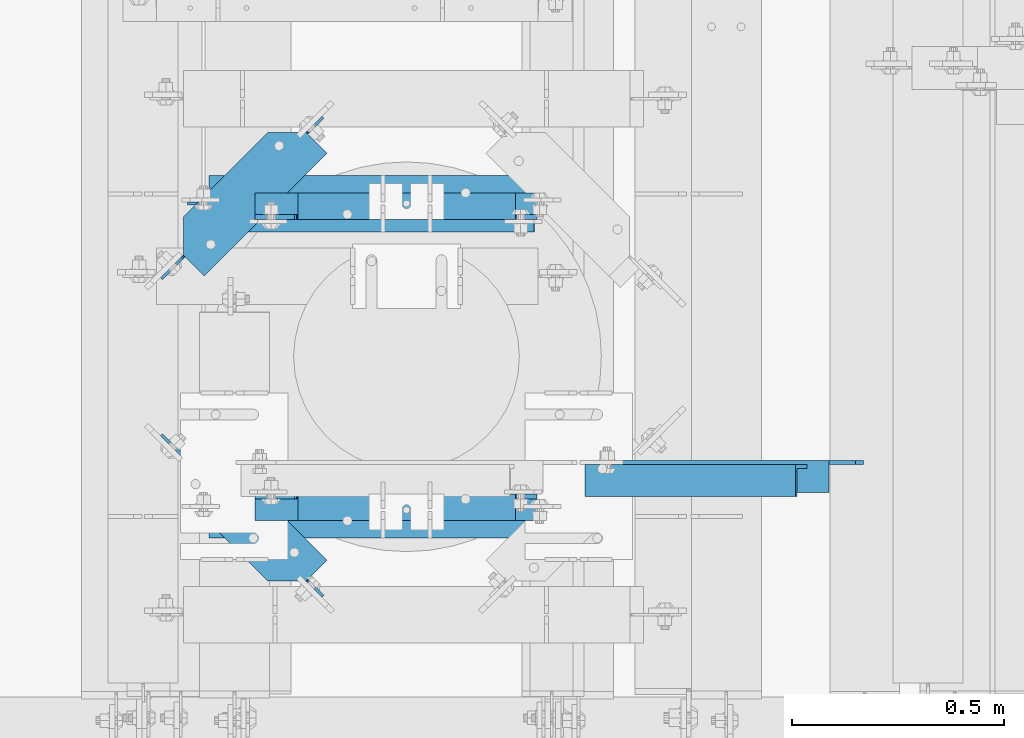
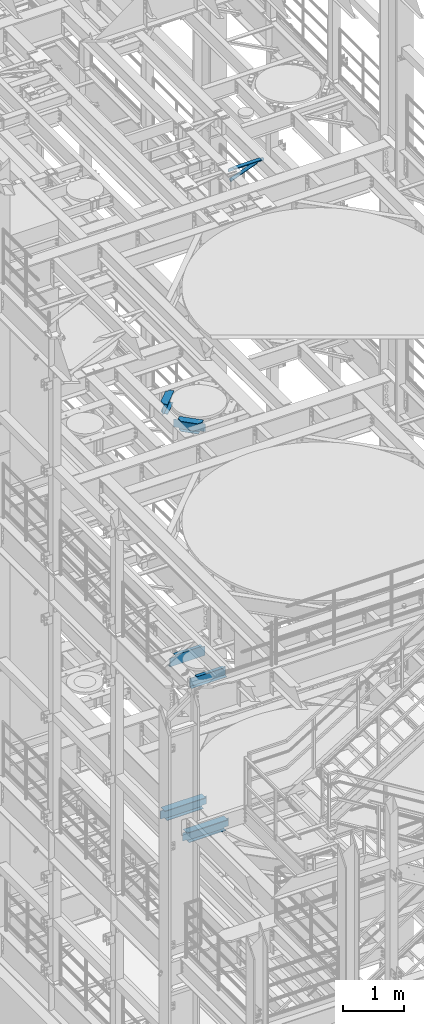
# One storey, part 1259 of 1876: 7 beams, 1 member, 8 elements without a shape of their own.
"""IFC2X3 building model written with IfcOpenShell, lengths in millimetres."""

from ifc_helpers import new_model, si_unit, frame, origin_with_axes, place, context, subcontext, project, spatial, faceted_brep, material, type_object, element, aggregate, save


model = new_model("IFC2X3")

# Units and contexts
model_context = context("Model", 3, precision=1e-05, world=origin_with_axes())
body_context = subcontext(model_context, "Body", "Model", "MODEL_VIEW")
ifc_project = project(units=[si_unit("LENGTHUNIT", "METRE", prefix="MILLI"), si_unit("AREAUNIT", "SQUARE_METRE"), si_unit("VOLUMEUNIT", "CUBIC_METRE"), si_unit("MASSUNIT", "GRAM", prefix="KILO"), si_unit("TIMEUNIT", "SECOND"), si_unit("PLANEANGLEUNIT", "RADIAN"), si_unit("SOLIDANGLEUNIT", "STERADIAN"), si_unit("THERMODYNAMICTEMPERATUREUNIT", "DEGREE_CELSIUS"), si_unit("LUMINOUSINTENSITYUNIT", "LUMEN")], contexts=[model_context])

# Site, building, storey
site_placement = place(None, origin_with_axes())
site = spatial("IfcSite", under=ifc_project, at=site_placement, CompositionType="ELEMENT")
building_placement = place(site_placement, origin_with_axes())
building = spatial("IfcBuilding", under=site, at=building_placement, Name="Undefined", CompositionType="ELEMENT")
storey_placement = place(building_placement, origin_with_axes())
storey = spatial("IfcBuildingStorey", under=building, at=storey_placement, Name="Undefined", CompositionType="ELEMENT", Elevation=0.0)

# Assembly, member
assembly_1_placement = place(storey_placement, origin_with_axes())
assembly_1 = element("IfcElementAssembly", 1, at=assembly_1_placement, inside=storey, AssemblyPlace="NOTDEFINED", PredefinedType="RIGID_FRAME")
ifc_material_1 = material(Name="STEEL/A36")
member_type = type_object("IfcMemberType", Name="L3X3X3/8", PredefinedType="NOTDEFINED")
member_placement = place(assembly_1_placement, frame((4825.99943782548, 2149.47737292659, 17722.85), z_axis=(0.0, -1.0, 0.0), x_axis=(0.933232749162593, -9.69999853849769e-08, 0.35927237006263)))
member = element("IfcMember", 2, at=member_placement, type_object=member_type, material=ifc_material_1, ObjectType="L3X3X3/8", context=body_context, shape_type="Brep", body=[
    faceted_brep([(31.6783539145181, 38.0999999999167, -38.1000000000035), (31.6783539102435, 38.1000000000477, 38.0999999999967), (563.830812318436, 38.100000000677, 38.0999999999349), (563.830812322711, 38.1000000005497, -38.1000000000654), (31.6783539102325, 28.5750000000644, 38.0999999999967), (563.830812318425, 28.5750000006938, 38.0999999999349), (31.6783539139742, 28.5749999999498, -28.5750000000039), (563.830812322169, 28.575000000581, -28.5750000000658), (31.6783539139069, -38.0999999999422, -28.5750000000044), (563.830812322098, -38.0999999993164, -28.5750000000662), (31.6783539144417, -38.099999999964, -38.1000000000045), (563.830812322634, -38.0999999993292, -38.1000000000663)], [[[0, 1, 2, 3]], [[1, 4, 5, 2]], [[4, 6, 7, 5]], [[6, 8, 9, 7]], [[8, 10, 11, 9]], [[10, 0, 3, 11]], [[5, 7, 9, 11, 3, 2]], [[10, 8, 6, 4, 1, 0]]]),
])
aggregate(assembly_1, [member])

# Assembly, beam
assembly_2_placement = place(storey_placement, origin_with_axes())
assembly_2 = element("IfcElementAssembly", 3, at=assembly_2_placement, inside=storey, Name="ANGLE", AssemblyPlace="NOTDEFINED", PredefinedType="RIGID_FRAME")
beam_type_1 = type_object("IfcBeamType", Name="L3X3X3/8", PredefinedType="NOTDEFINED")
beam_1_placement = place(assembly_2_placement, frame((4826.00006225236, 2159.00237292652, 17945.1), z_axis=(0.0, -1.0, 0.0), x_axis=(1.0, 0.0, 0.0)))
beam_1 = element("IfcBeam", 4, at=beam_1_placement, type_object=beam_type_1, material=ifc_material_1, Name="ANGLE", ObjectType="L3X3X3/8", context=body_context, shape_type="Brep", body=[
    faceted_brep([(592.137879206581, 28.5750000000007, -28.5750000001131), (592.137886141031, 28.5750000000007, 38.0999999998871), (84.1369379238226, 28.5750017223108, 38.099999999984), (84.1369309896222, 28.5750000000007, -28.5750000000166), (592.137552829826, 38.0999999999985, 38.0999999998871), (84.1373129237786, 38.0999999999985, 38.0999999999835), (22.2249324870172, 28.5750000000007, -28.5750000000048), (22.2249314964174, 28.5750108662178, -38.1000000000049), (3.17493225935686, 9.52501162915723, -38.1000000000013), (3.17493324995667, 9.52501048616614, -28.5750000000012), (84.1369299990224, 28.5750108662141, -38.1000000000167), (84.1373049986182, 38.0999999999985, -38.1000000000167), (592.13754490474, 38.0999999999985, -38.1000000001131), (592.137934775866, 26.9870022607502, -28.5750000001131), (592.137933785266, 26.9870012415704, -38.1000000001131), (654.049937080378, 26.9870022607502, -28.5750000001249), (654.049936089778, 26.9870012415704, -38.100000000125), (673.099936317439, 7.93700302368961, -28.5750000001285), (673.099935326839, 7.93700200450985, -38.1000000001286), (673.099936317439, 1.58700264221989, -28.5750000001285), (673.099935326839, 1.58700162304012, -38.1000000001286), (673.099934791558, -38.0999999999985, -28.5750000001285), (673.099933800958, -38.0999999999985, -38.1000000001286), (3.17493098964678, -38.0999999999985, -28.5750000000012), (3.17492999904698, -38.0999999999985, -38.1000000000013), (3.17492847316589, 3.17501220136182, -38.1000000000013), (3.17492946376569, 3.17501105837073, -28.5750000000012)], [[[0, 1, 2, 3]], [[1, 4, 5, 2]], [[6, 7, 8, 9]], [[3, 10, 7, 6]], [[2, 5, 11, 10, 3]], [[4, 12, 11, 5]], [[1, 0, 13, 14, 12, 4]], [[15, 16, 14, 13]], [[17, 18, 16, 15]], [[19, 20, 18, 17]], [[20, 19, 21, 22]], [[22, 21, 23, 24]], [[8, 7, 10, 11, 12, 14, 16, 18, 20, 22, 24, 25]], [[9, 8, 25, 26]], [[21, 19, 17, 15, 13, 0, 3, 6, 9, 26, 23]], [[25, 24, 23, 26]]]),
])
aggregate(assembly_2, [beam_1])

assembly_3_placement = place(storey_placement, origin_with_axes())
assembly_3 = element("IfcElementAssembly", 5, at=assembly_3_placement, inside=storey, Name="BEAM", AssemblyPlace="NOTDEFINED", PredefinedType="RIGID_FRAME")
ifc_material_2 = material(Name="STEEL/A992")
beam_type_2 = type_object("IfcBeamType", Name="W8X18", PredefinedType="NOTDEFINED")
beam_2_placement = place(assembly_3_placement, frame((3797.3, 2300.55425635799, 13206.4125), z_axis=(0.0, 0.0, 1.0), x_axis=(0.707104099181461, -0.707109463181462, 0.0)))
beam_2 = element("IfcBeam", 6, at=beam_2_placement, type_object=beam_type_2, material=ifc_material_2, Name="BEAM", ObjectType="W8X18", context=body_context, shape_type="Brep", body=[
    faceted_brep([(61.5469102724485, -3.17500000000564, -77.7875000000004), (61.5469102724435, 3.17499999999382, -77.7875000000004), (137.746380590202, 3.17499999998745, -77.7875000000004), (137.746380590201, -3.17500000001201, -77.7875000000004), (142.606460108247, 3.17499999998745, -78.7542299225879), (142.606460108246, -3.17500000001291, -78.7542299225879), (146.7266365764, 3.17499999998745, -81.5072438230654), (146.7266365764, -3.17500000001291, -81.5072438230654), (149.479650476878, 3.17499999998654, -85.6274202912191), (149.479650476877, -3.17500000001291, -85.6274202912191), (150.446380399465, -3.17500000001291, -90.4874998092655), (150.446380399465, 3.17499999998654, -90.4874998092655), (150.446380399465, 3.17499999998654, -95.25), (150.446380399471, 66.6749999999847, -95.25), (150.446380399471, 66.6749999999847, -103.1875), (150.446380399464, -15.7419074005238, -103.1875), (150.446380399464, -15.741907400522, -95.25), (150.446380399465, -3.17500000001291, -95.25), (483.741355979041, -66.6750000000384, -103.1875), (483.741355979041, -66.6750000000384, -95.25), (201.379858527849, -66.6750000000102, -95.25), (201.379858527849, -66.6750000000147, -103.1875), (499.521676769977, -50.8945595016339, -103.1875), (499.521676769977, -50.8945599597382, -95.25), (483.741355979041, -66.6750000000384, 95.25), (483.741355979041, -66.6750000000384, 103.1875), (201.379858527849, -66.6750000000102, 103.1875), (201.379858527849, -66.6750000000147, 95.25), (137.879377876005, -3.17500000001201, 103.1875), (137.879377876005, -3.17500000001201, 95.25), (547.240876123301, -3.17500000004566, 95.25), (547.240876123301, -3.17499815664814, 103.1875), (547.146676769977, 66.674999999952, 103.1875), (137.746380399474, 66.6749999999856, 103.1875), (547.146676769977, 66.674999999952, 95.25), (547.146676769972, 3.1749999999538, 95.25), (137.746380399468, 3.17499999998745, 95.25), (137.746380399474, 66.6749999999856, 95.25), (125.046380590204, -3.1750000000111, 77.7875000000004), (125.046380590204, 3.17499999998836, 77.7875000000004), (61.5469102724435, 3.17499999999382, 77.7875000000004), (61.5469102724485, -3.17500000000564, 77.7875000000004), (129.906460108249, -3.1750000000111, 78.7542299225879), (129.90646010825, 3.17499999998836, 78.7542299225879), (134.026636576402, -3.17500000001201, 81.5072438230654), (134.026636576403, 3.17499999998836, 81.5072438230654), (136.77965047688, -3.17500000001201, 85.6274202912191), (136.779650476881, 3.17499999998745, 85.6274202912191), (137.746380399468, -3.17500000001201, 90.4874998092655), (137.746380399468, 3.17499999998745, 90.4874998092655), (547.146676770065, -3.17499999995425, 90.4874998092655), (547.146676770069, 3.17499997963523, 90.4874998092655), (548.113406692652, -3.17499999995403, 85.6274202912191), (548.113406692656, 3.17499997923346, 85.6274202912191), (550.86642059313, -3.1749999999538, 81.5072438230654), (550.866420593134, 3.17499997889263, 81.5072438230654), (554.986597061284, -3.17499999995357, 78.7542299225879), (554.986597061287, 3.17499997866548, 78.7542299225879), (559.846676579328, -3.17499999995289, 77.7875000000004), (559.846676579332, 3.1749999785859, 77.7875000000004), (601.122206639045, -3.1749999999497, 77.7875000000004), (601.122206639281, 3.1750000000477, 77.7875000000004), (601.122206639045, -3.1749999999497, -77.7875000000004), (601.122206639281, 3.1750000000477, -77.7875000000004), (512.221676579338, -3.17499999995698, -77.7875000000004), (512.221676579342, 3.17499996473862, -77.7875000000004), (507.361597061294, -3.17499999995789, -78.7542299225879), (507.361597061296, 3.17499996467791, -78.7542299225879), (503.24142059314, -3.17499999995721, -81.5072438230654), (503.241420593144, 3.17499996447827, -81.5072438230654), (500.488406692662, -3.17499999995835, -85.6274202912191), (500.488406692665, 3.17499996416927, -85.6274202912191), (499.521676770074, -3.17499999995835, -90.4874998092655), (499.521676770079, 3.17499996379797, -90.4874998092655), (499.521676770028, -3.17499999995789, -95.25), (499.521676769986, 66.6749999999565, -103.1875), (499.521676769986, 66.6749999999565, -95.25), (499.521676770028, 3.17500000003929, -95.25)], [[[0, 1, 2, 3]], [[3, 2, 4, 5]], [[5, 4, 6, 7]], [[7, 6, 8, 9]], [[10, 11, 12, 13, 14, 15, 16, 17]], [[9, 8, 11, 10]], [[18, 19, 20, 21]], [[19, 18, 22, 23]], [[24, 25, 26, 27]], [[27, 26, 28, 29]], [[30, 24, 27, 29]], [[25, 24, 30, 31]], [[26, 25, 31, 32, 33, 28]], [[34, 35, 36, 37]], [[38, 39, 40, 41]], [[42, 43, 39, 38]], [[44, 45, 43, 42]], [[46, 47, 45, 44]], [[48, 49, 47, 46]], [[28, 33, 37, 36, 49, 48, 29]], [[32, 34, 37, 33]], [[31, 30, 50, 51, 35, 34, 32]], [[52, 53, 51, 50]], [[54, 55, 53, 52]], [[56, 57, 55, 54]], [[58, 59, 57, 56]], [[60, 61, 59, 58]], [[61, 60, 62, 63]], [[62, 64, 65, 63]], [[66, 67, 65, 64]], [[68, 69, 67, 66]], [[70, 71, 69, 68]], [[72, 73, 71, 70]], [[74, 23, 22, 75, 76, 77, 73, 72]], [[20, 19, 23, 74, 17, 16]], [[21, 20, 16, 15]], [[75, 22, 18, 21, 15, 14]], [[76, 75, 14, 13]], [[77, 76, 13, 12]], [[6, 4, 2, 1, 40, 39, 43, 45, 47, 49, 36, 35, 51, 53, 55, 57, 59, 61, 63, 65, 67, 69, 71, 73, 77, 12, 11, 8]], [[41, 40, 1, 0]], [[74, 72, 70, 68, 66, 64, 62, 60, 58, 56, 54, 52, 50, 30, 29, 48, 46, 44, 42, 38, 41, 0, 3, 5, 7, 9, 10, 17]]]),
])
aggregate(assembly_3, [beam_2])

assembly_4_placement = place(storey_placement, origin_with_axes())
assembly_4 = element("IfcElementAssembly", 7, at=assembly_4_placement, inside=storey, Name="BEAM", AssemblyPlace="NOTDEFINED", PredefinedType="RIGID_FRAME")
beam_3_placement = place(assembly_4_placement, frame((3797.3, 2582.59574364201, 13206.4125), z_axis=(0.0, 0.0, 1.0), x_axis=(0.707104099181461, 0.707109463181462, 0.0)))
beam_3 = element("IfcBeam", 8, at=beam_3_placement, type_object=beam_type_2, material=ifc_material_2, Name="BEAM", ObjectType="W8X18", context=body_context, shape_type="Brep", body=[
    faceted_brep([(61.5469102724485, -3.17500000000564, 77.7875000000004), (61.5469102724435, 3.17499999999382, 77.7875000000004), (61.5469102724435, 3.17499999999382, -77.7875000000004), (61.5469102724485, -3.17500000000564, -77.7875000000004), (483.741355979063, 66.6750000000156, -103.1875), (499.521676770023, 50.8945595016301, -103.1875), (499.521676770033, -66.6749999999354, -103.1875), (150.446380399347, -66.6749999999852, -103.1875), (150.446380399339, 15.7419074003969, -103.1875), (201.37985852787, 66.6749999999925, -103.1875), (499.521676770033, -66.6749999999354, -95.25), (150.446380399347, -66.6749999999852, -95.25), (499.521676770028, -3.17499999995789, -95.25), (150.446380399465, -3.17500000001291, -95.25), (137.746380590201, -3.17500000001201, -77.7875000000004), (137.746380590202, 3.17499999998745, -77.7875000000004), (142.606460108247, 3.17499999998745, -78.7542299225879), (142.606460108246, -3.17500000001291, -78.7542299225879), (146.7266365764, 3.17499999998745, -81.5072438230654), (146.7266365764, -3.17500000001291, -81.5072438230654), (149.479650476878, 3.17499999998654, -85.6274202912191), (149.479650476877, -3.17500000001291, -85.6274202912191), (150.446380399465, 3.17499999998654, -90.4874998092655), (150.446380399465, -3.17500000001291, -90.4874998092655), (150.446380399465, 3.17499999998654, -95.25), (499.521676770028, 3.17500000003929, -95.25), (499.521676770023, 50.8945599596909, -95.25), (483.741355979063, 66.6750000000156, -95.25), (201.37985852787, 66.6750000000313, -95.25), (150.446380399339, 15.7419074003969, -95.25), (499.521676770079, 3.17499996379797, -90.4874998092655), (499.521676770074, -3.17499999995835, -90.4874998092655), (500.488406692665, 3.17499996416927, -85.6274202912191), (500.488406692662, -3.17499999995835, -85.6274202912191), (503.241420593144, 3.17499996447827, -81.5072438230654), (503.24142059314, -3.17499999995721, -81.5072438230654), (507.361597061296, 3.17499996467791, -78.7542299225879), (507.361597061294, -3.17499999995789, -78.7542299225879), (512.221676579342, 3.17499996473862, -77.7875000000004), (512.221676579338, -3.17499999995698, -77.7875000000004), (601.122206639045, -3.1749999999497, -77.7875000000004), (601.122206639281, 3.1750000000477, -77.7875000000004), (601.122206639281, 3.1750000000477, 77.7875000000004), (601.122206639045, -3.1749999999497, 77.7875000000004), (559.846676579332, 3.1749999785859, 77.7875000000004), (559.846676579328, -3.17499999995289, 77.7875000000004), (554.986597061287, 3.17499997866548, 78.7542299225879), (554.986597061284, -3.17499999995357, 78.7542299225879), (550.866420593134, 3.17499997889263, 81.5072438230654), (550.86642059313, -3.1749999999538, 81.5072438230654), (548.113406692656, 3.17499997923346, 85.6274202912191), (548.113406692652, -3.17499999995403, 85.6274202912191), (547.146676770069, 3.17499997963523, 90.4874998092655), (547.146676770065, -3.17499999995425, 90.4874998092655), (547.146676770018, -3.1749999999538, 95.25), (547.146676770023, -66.6749999999315, 95.25), (137.746380399351, -66.6749999999863, 95.25), (137.746380399345, -3.17499999998813, 95.25), (547.146676770023, -66.6749999999315, 103.1875), (137.746380399351, -66.6749999999863, 103.1875), (137.746380399344, 3.17500000001132, 103.1875), (547.146676769945, 3.26919822458831, 103.1875), (483.741355979063, 66.6750000000156, 103.1875), (201.37985852787, 66.6750000000313, 103.1875), (137.879377390637, 3.17500048591205, 103.1875), (483.741355979063, 66.6750000000156, 95.25), (201.37985852787, 66.6749999999925, 95.25), (547.146676769945, 3.26919822458831, 95.25), (547.146676769972, 3.1749999999538, 95.25), (137.879377390637, 3.17500000000996, 95.25), (137.746380399468, 3.17499999998745, 95.25), (137.746380399468, 3.17499999998745, 90.4874998092655), (137.746380399468, -3.17500000001201, 90.4874998092655), (136.779650476881, 3.17499999998745, 85.6274202912191), (136.77965047688, -3.17500000001201, 85.6274202912191), (134.026636576403, 3.17499999998836, 81.5072438230654), (134.026636576402, -3.17500000001201, 81.5072438230654), (129.90646010825, 3.17499999998836, 78.7542299225879), (129.906460108249, -3.1750000000111, 78.7542299225879), (125.046380590204, 3.17499999998836, 77.7875000000004), (125.046380590204, -3.1750000000111, 77.7875000000004)], [[[0, 1, 2, 3]], [[4, 5, 6, 7, 8, 9]], [[6, 10, 11, 7]], [[10, 12, 13, 11]], [[14, 15, 16, 17]], [[17, 16, 18, 19]], [[19, 18, 20, 21]], [[21, 20, 22, 23]], [[24, 25, 26, 27, 28, 29]], [[7, 11, 13, 23, 22, 24, 29, 8]], [[28, 9, 8, 29]], [[27, 4, 9, 28]], [[4, 27, 26, 5]], [[12, 10, 6, 5, 26, 25, 30, 31]], [[31, 30, 32, 33]], [[33, 32, 34, 35]], [[35, 34, 36, 37]], [[37, 36, 38, 39]], [[40, 39, 38, 41]], [[42, 43, 40, 41]], [[43, 42, 44, 45]], [[45, 44, 46, 47]], [[47, 46, 48, 49]], [[49, 48, 50, 51]], [[51, 50, 52, 53]], [[54, 55, 56, 57]], [[55, 58, 59, 56]], [[60, 59, 58, 61, 62, 63, 64]], [[62, 65, 66, 63]], [[61, 67, 65, 62]], [[58, 55, 54, 53, 52, 68, 67, 61]], [[65, 67, 68, 69, 66]], [[63, 66, 69, 64]], [[64, 69, 70, 60]], [[71, 72, 57, 56, 59, 60, 70]], [[72, 71, 73, 74]], [[74, 73, 75, 76]], [[76, 75, 77, 78]], [[78, 77, 79, 80]], [[14, 17, 19, 21, 23, 13, 12, 31, 33, 35, 37, 39, 40, 43, 45, 47, 49, 51, 53, 54, 57, 72, 74, 76, 78, 80, 0, 3]], [[3, 2, 15, 14]], [[79, 77, 75, 73, 71, 70, 69, 68, 52, 50, 48, 46, 44, 42, 41, 38, 36, 34, 32, 30, 25, 24, 22, 20, 18, 16, 15, 2, 1]], [[80, 79, 1, 0]]]),
])
aggregate(assembly_4, [beam_3])

assembly_5_placement = place(storey_placement, origin_with_axes())
assembly_5 = element("IfcElementAssembly", 9, at=assembly_5_placement, inside=storey, Name="BEAM", AssemblyPlace="NOTDEFINED", PredefinedType="RIGID_FRAME")
beam_4_placement = place(assembly_5_placement, frame((3886.2, 2803.525, 5027.6125), z_axis=(0.0, 0.0, -1.0), x_axis=(1.0, 0.0, 0.0)))
beam_4 = element("IfcBeam", 10, at=beam_4_placement, type_object=beam_type_2, material=ifc_material_2, Name="BEAM", ObjectType="W8X18", context=body_context, shape_type="Brep", body=[
    faceted_brep([(835.025000000001, -66.6750000000002, -103.1875), (835.025000000001, 66.6750000000002, -103.1875), (835.025000000001, 66.6750000000002, -96.837499809264), (835.025000000001, -66.6750000000002, -96.837499809264), (835.340773345276, -3.17500000000018, -95.25), (835.340773345276, -66.6750000000002, -95.25), (835.340773345276, 66.6750000000002, -95.25), (835.340773345276, 3.17500000000018, -95.25), (835.991729922588, 3.17500000000018, -91.9774202912186), (835.991729922588, -3.17500000000018, -91.9774202912186), (838.744743823067, 3.17500000000018, -87.8572438230649), (838.744743823067, -3.17500000000018, -87.8572438230649), (842.86492029122, 3.17500000000018, -85.1042299225865), (842.86492029122, -3.17500000000018, -85.1042299225865), (847.724999809266, 3.17500000000018, -84.1374999999989), (847.724999809266, -3.17500000000018, -84.1374999999989), (885.825000000001, -3.17500000000018, -84.1374999999989), (885.825000000001, 3.17500000000018, -84.1374999999989), (104.775, 3.17500000000018, 95.25), (104.775, 66.6750000000002, 95.25), (796.925000000001, 66.6750000000002, 95.25), (796.925000000001, 3.17500000000018, 95.25), (66.675000000002, -66.6750000000002, -96.837499809264), (66.675000000002, 66.6750000000002, -96.837499809264), (66.675000000002, 66.6750000000002, -103.1875), (66.675000000002, -66.6750000000002, -103.1875), (66.3592266547266, -66.6750000000002, -95.25), (66.3592266547266, -3.17500000000018, -95.25), (65.708270077414, -3.17500000000018, -91.9774202912186), (65.708270077414, 3.17500000000018, -91.9774202912186), (66.3592266547266, 3.17500000000018, -95.25), (66.3592266547266, 66.6750000000002, -95.25), (62.955256176936, -3.17500000000018, -87.8572438230649), (62.955256176936, 3.17500000000018, -87.8572438230649), (58.8350797087824, -3.17500000000018, -85.1042299225865), (58.8350797087824, 3.17500000000018, -85.1042299225865), (53.9750001907369, -3.17500000000018, -84.1374999999989), (53.9750001907369, 3.17500000000018, -84.1374999999989), (15.875, -3.17500000000018, -84.1375000000007), (15.875, 3.17500000000018, -84.1375000000007), (15.875, -3.17500000000018, 77.7874999999949), (15.875, 3.17500000000018, 77.7874999999949), (92.0750001907368, -3.17500000000018, 77.7875000000013), (92.0750001907368, 3.17500000000018, 77.7875000000013), (96.9350797087823, -3.17500000000018, 78.7542299225888), (96.9350797087823, 3.17500000000018, 78.7542299225888), (101.055256176936, -3.17500000000018, 81.5072438230673), (101.055256176936, 3.17500000000018, 81.5072438230673), (103.808270077414, -3.17500000000018, 85.6274202912209), (103.808270077414, 3.17500000000018, 85.6274202912209), (104.775000000002, -3.17500000000018, 90.4874998092664), (104.775000000002, 3.17500000000018, 90.4874998092664), (104.775, -66.6750000000002, 103.1875), (104.775, 66.6750000000002, 103.1875), (104.775, -3.17500000000018, 95.25), (104.775, -66.6750000000002, 95.25), (796.925000000001, -3.17500000000018, 95.25), (796.925000000001, -66.6750000000002, 95.25), (796.925000000001, -66.6750000000002, 103.1875), (796.925000000001, 66.6750000000002, 103.1875), (796.925000000001, -3.17500000000018, 90.4874998092664), (796.925000000001, 3.17500000000018, 90.4874998092664), (797.891729922589, -3.17500000000018, 85.6274202912209), (797.891729922589, 3.17500000000018, 85.6274202912209), (800.644743823067, -3.17500000000018, 81.5072438230673), (800.644743823067, 3.17500000000018, 81.5072438230673), (804.764920291221, -3.17500000000018, 78.7542299225888), (804.764920291221, 3.17500000000018, 78.7542299225888), (809.624999809266, -3.17500000000018, 77.7875000000013), (809.624999809266, 3.17500000000018, 77.7875000000013), (885.825000000001, -3.17500000000018, 77.7875000000013), (885.825000000001, 3.17500000000018, 77.7875000000013)], [[[0, 1, 2, 3]], [[4, 5, 3, 2, 6, 7, 8, 9]], [[9, 8, 10, 11]], [[11, 10, 12, 13]], [[13, 12, 14, 15]], [[16, 15, 14, 17]], [[18, 19, 20, 21]], [[22, 23, 24, 25]], [[26, 27, 28, 29, 30, 31, 23, 22]], [[32, 33, 29, 28]], [[34, 35, 33, 32]], [[36, 37, 35, 34]], [[38, 39, 37, 36]], [[40, 41, 39, 38]], [[42, 43, 41, 40]], [[44, 45, 43, 42]], [[46, 47, 45, 44]], [[48, 49, 47, 46]], [[50, 51, 49, 48]], [[52, 53, 19, 18, 51, 50, 54, 55]], [[55, 54, 56, 57]], [[52, 55, 57, 58]], [[53, 52, 58, 59]], [[19, 53, 59, 20]], [[58, 57, 56, 60, 61, 21, 20, 59]], [[62, 63, 61, 60]], [[64, 65, 63, 62]], [[66, 67, 65, 64]], [[68, 69, 67, 66]], [[70, 71, 69, 68]], [[71, 70, 16, 17]], [[12, 10, 8, 7, 30, 29, 33, 35, 37, 39, 41, 43, 45, 47, 49, 51, 18, 21, 61, 63, 65, 67, 69, 71, 17, 14]], [[31, 30, 7, 6]], [[1, 24, 23, 31, 6, 2]], [[25, 24, 1, 0]], [[26, 22, 25, 0, 3, 5]], [[27, 26, 5, 4]], [[70, 68, 66, 64, 62, 60, 56, 54, 50, 48, 46, 44, 42, 40, 38, 36, 34, 32, 28, 27, 4, 9, 11, 13, 15, 16]]]),
])
aggregate(assembly_5, [beam_4])

assembly_6_placement = place(storey_placement, origin_with_axes())
assembly_6 = element("IfcElementAssembly", 11, at=assembly_6_placement, inside=storey, Name="BEAM", AssemblyPlace="NOTDEFINED", PredefinedType="RIGID_FRAME")
beam_5_placement = place(assembly_6_placement, frame((3886.2, 2079.625, 5027.6125), z_axis=(0.0, 0.0, 1.0), x_axis=(1.0, 0.0, 0.0)))
beam_5 = element("IfcBeam", 12, at=beam_5_placement, type_object=beam_type_2, material=ifc_material_2, Name="BEAM", ObjectType="W8X18", context=body_context, shape_type="Brep", body=[
    faceted_brep([(15.875, -3.17500000000018, -77.7874999999949), (15.875, 3.17500000000018, -77.7874999999949), (92.0750001907354, 3.17500000000018, -77.7875000000022), (92.0750001907354, -3.17500000000018, -77.7875000000022), (96.9350797087809, 3.17500000000018, -78.7542299225897), (96.9350797087809, -3.17500000000018, -78.7542299225897), (101.055256176935, 3.17500000000018, -81.5072438230673), (101.055256176935, -3.17500000000018, -81.5072438230673), (103.808270077413, 3.17500000000018, -85.6274202912209), (103.808270077413, -3.17500000000018, -85.6274202912209), (104.775000000001, -3.17500000000018, -90.4874998092673), (104.775000000001, 3.17500000000018, -90.4874998092673), (104.775000000001, 3.17500000000018, -95.25), (104.775000000001, 66.6750000000002, -95.25), (104.775000000001, 66.6750000000002, -103.1875), (104.775000000001, -66.6750000000002, -103.1875), (104.775000000001, -66.6750000000002, -95.25), (104.775000000001, -3.17500000000018, -95.25), (66.6749999999997, 66.6750000000002, 103.1875), (66.6749999999997, -66.675, 103.1875), (835.024999999998, -66.675, 103.1875), (835.024999999998, 66.6750000000002, 103.1875), (66.6749999999997, 66.6750000000002, 96.837499809264), (66.6749999999997, -66.675, 96.837499809264), (66.3592266547244, -66.675, 95.25), (835.340773345274, -66.675, 95.25), (835.024999999998, -66.675, 96.837499809264), (835.024999999998, 66.6750000000002, 96.837499809264), (66.3592266547244, 66.6750000000002, 95.25), (835.340773345274, 66.6750000000002, 95.25), (66.3592266547244, 3.17500000000018, 95.25), (835.340773345274, 3.17500000000018, 95.25), (53.9750001907346, -3.17500000000018, 84.1374999999989), (53.9750001907346, 3.17500000000018, 84.1374999999989), (15.875, 3.17500000000018, 84.1375000000044), (15.875, -3.17500000000018, 84.1375000000044), (58.8350797087801, -3.17500000000018, 85.1042299225865), (58.8350797087801, 3.17500000000018, 85.1042299225865), (62.9552561769337, -3.17500000000018, 87.8572438230649), (62.9552561769337, 3.17500000000018, 87.8572438230649), (65.7082700774117, -3.17500000000018, 91.9774202912186), (65.7082700774117, 3.17500000000018, 91.9774202912186), (66.3592266547244, -3.17500000000018, 95.25), (835.340773345274, -3.17500000000018, 95.25), (835.991729922586, -3.17500000000018, 91.9774202912186), (835.991729922586, 3.17500000000018, 91.9774202912186), (838.744743823064, -3.17500000000018, 87.8572438230649), (838.744743823064, 3.17500000000018, 87.8572438230649), (842.864920291218, -3.17500000000018, 85.1042299225865), (842.864920291218, 3.17500000000018, 85.1042299225865), (847.724999809263, -3.17500000000018, 84.1374999999989), (847.724999809263, 3.17500000000018, 84.1374999999989), (885.824999999998, -3.17500000000018, 84.1374999999989), (885.824999999998, 3.17500000000018, 84.1374999999989), (885.824999999998, -3.17500000000018, -77.7875000000013), (885.824999999998, 3.17500000000018, -77.7875000000013), (809.624999809264, -3.17500000000018, -77.7875000000013), (809.624999809264, 3.17500000000018, -77.7875000000013), (804.764920291218, -3.17500000000018, -78.7542299225888), (804.764920291218, 3.17500000000018, -78.7542299225888), (800.644743823065, -3.17500000000018, -81.5072438230673), (800.644743823065, 3.17500000000018, -81.5072438230673), (797.891729922586, -3.17500000000018, -85.6274202912209), (797.891729922586, 3.17500000000018, -85.6274202912209), (796.924999999999, -3.17500000000018, -90.4874998092664), (796.924999999999, 3.17500000000018, -90.4874998092664), (796.924999999999, -3.17500000000018, -95.25), (796.924999999999, -66.675, -95.25), (796.924999999999, -66.675, -103.1875), (796.924999999999, 66.6750000000002, -103.1875), (796.924999999999, 66.6750000000002, -95.25), (796.924999999999, 3.17500000000018, -95.25)], [[[0, 1, 2, 3]], [[3, 2, 4, 5]], [[5, 4, 6, 7]], [[7, 6, 8, 9]], [[10, 11, 12, 13, 14, 15, 16, 17]], [[9, 8, 11, 10]], [[18, 19, 20, 21]], [[19, 18, 22, 23]], [[20, 19, 23, 24, 25, 26]], [[20, 26, 27, 21]], [[28, 22, 18, 21, 27, 29]], [[30, 28, 29, 31]], [[32, 33, 34, 35]], [[36, 37, 33, 32]], [[38, 39, 37, 36]], [[40, 41, 39, 38]], [[23, 22, 28, 30, 41, 40, 42, 24]], [[24, 42, 43, 25]], [[44, 45, 31, 29, 27, 26, 25, 43]], [[46, 47, 45, 44]], [[48, 49, 47, 46]], [[50, 51, 49, 48]], [[52, 53, 51, 50]], [[53, 52, 54, 55]], [[54, 56, 57, 55]], [[58, 59, 57, 56]], [[60, 61, 59, 58]], [[62, 63, 61, 60]], [[64, 65, 63, 62]], [[66, 67, 68, 69, 70, 71, 65, 64]], [[67, 66, 17, 16]], [[68, 67, 16, 15]], [[69, 68, 15, 14]], [[70, 69, 14, 13]], [[71, 70, 13, 12]], [[6, 4, 2, 1, 34, 33, 37, 39, 41, 30, 31, 45, 47, 49, 51, 53, 55, 57, 59, 61, 63, 65, 71, 12, 11, 8]], [[35, 34, 1, 0]], [[66, 64, 62, 60, 58, 56, 54, 52, 50, 48, 46, 44, 43, 42, 40, 38, 36, 32, 35, 0, 3, 5, 7, 9, 10, 17]]]),
])
aggregate(assembly_6, [beam_5])

assembly_7_placement = place(storey_placement, origin_with_axes())
assembly_7 = element("IfcElementAssembly", 13, at=assembly_7_placement, inside=storey, Name="BEAM", AssemblyPlace="NOTDEFINED", PredefinedType="RIGID_FRAME")
beam_type_3 = type_object("IfcBeamType", Name="C8X18.75", PredefinedType="NOTDEFINED")
beam_6_placement = place(assembly_7_placement, frame((4070.35, 2797.17216796875, 8051.8), z_axis=(0.0, 0.0, -1.0), x_axis=(1.0, 0.0, 0.0)))
beam_6 = element("IfcBeam", 14, at=beam_6_placement, type_object=beam_type_3, material=ifc_material_1, Name="BEAM", ObjectType="C8X18.75", context=body_context, shape_type="Brep", body=[
    faceted_brep([(-8.73162035838459, 19.0500000000002, -69.8499999999995), (-8.73162035838459, 31.75, -69.8499999999995), (80.1683798323502, 31.75, -69.8499999999995), (80.1683798323502, 19.0500000000002, -69.8499999999995), (85.0284593503957, 31.75, -70.816729922587), (85.0284593503957, 19.0500000000002, -70.816729922587), (89.1486358185493, 31.75, -73.5697438230654), (89.1486358185493, 19.0500000000002, -73.5697438230654), (91.9016497190278, 31.75, -77.6899202912191), (91.9016497190278, 19.0500000000002, -77.6899202912191), (92.8683796416153, 19.0500000000002, -82.5499998092646), (92.8683796416153, 31.75, -82.5499998092646), (92.8683796416153, 31.75, -101.6), (92.8683796416153, -31.75, -101.6), (92.8683796416153, -31.75, -97.3645500000002), (92.8683796416153, 19.0500000000002, -88.9012700000003), (606.425, -31.75, -97.3645500000002), (606.425, -31.75, -101.6), (606.425, 31.75, -101.6), (606.425, 31.75, -95.2499998092644), (606.425, -19.0576219043483, -95.2499998092644), (607.391729922588, 31.75, -90.3899202912189), (607.391729922588, 10.1145240623118, -90.3899202912189), (-8.73162035838459, 31.75, 101.6), (-8.73162035838459, -31.75, 101.6), (657.224999999999, -31.75, 101.6), (657.224999999999, 31.75, 101.6), (-8.73162035838459, -31.75, 97.3645500000002), (657.224999999999, -31.75, 97.3645500000002), (-8.73162035838459, 19.0500000000002, 88.9012700000003), (657.224999999999, 19.0500000000002, 88.9012700000003), (657.224999999999, 19.0500000000002, -82.5499999999993), (657.224999999999, 31.75, -82.5499999999993), (619.124999809265, 19.0500000000002, -82.5499999999993), (619.124999809265, 31.75, -82.5499999999993), (614.26492029122, 19.0500000000002, -83.5167299225868), (614.26492029122, 31.75, -83.5167299225868), (610.144743823066, 19.0500000000002, -86.2697438230653), (610.144743823066, 31.75, -86.2697438230653), (608.386414246513, 19.0500000000002, -88.9012700000003)], [[[0, 1, 2, 3]], [[3, 2, 4, 5]], [[5, 4, 6, 7]], [[7, 6, 8, 9]], [[10, 11, 12, 13, 14, 15]], [[9, 8, 11, 10]], [[16, 17, 18, 19, 20]], [[20, 19, 21, 22]], [[23, 24, 25, 26]], [[24, 27, 28, 25]], [[27, 29, 30, 28]], [[26, 25, 28, 30, 31, 32]], [[31, 33, 34, 32]], [[35, 36, 34, 33]], [[37, 38, 36, 35]], [[39, 22, 21, 38, 37]], [[16, 20, 22, 39, 15, 14]], [[17, 16, 14, 13]], [[18, 17, 13, 12]], [[6, 4, 2, 1, 23, 26, 32, 34, 36, 38, 21, 19, 18, 12, 11, 8]], [[29, 27, 24, 23, 1, 0]], [[39, 37, 35, 33, 31, 30, 29, 0, 3, 5, 7, 9, 10, 15]]]),
])
aggregate(assembly_7, [beam_6])

assembly_8_placement = place(storey_placement, origin_with_axes())
assembly_8 = element("IfcElementAssembly", 15, at=assembly_8_placement, inside=storey, Name="BEAM", AssemblyPlace="NOTDEFINED", PredefinedType="RIGID_FRAME")
beam_7_placement = place(assembly_8_placement, frame((4070.35, 2085.97232666016, 8051.8), z_axis=(0.0, 0.0, 1.0), x_axis=(1.0, 0.0, 0.0)))
beam_7 = element("IfcBeam", 16, at=beam_7_placement, type_object=beam_type_3, material=ifc_material_1, Name="BEAM", ObjectType="C8X18.75", context=body_context, shape_type="Brep", body=[
    faceted_brep([(80.1683798323502, 19.0500000000002, 69.8500000000004), (80.1683798323502, 31.75, 69.8500000000004), (-8.73162035838459, 31.75, 69.8500000000004), (-8.73162035838459, 19.0500000000002, 69.8500000000004), (85.0284593503957, 19.0500000000002, 70.8167299225879), (85.0284593503957, 31.75, 70.8167299225879), (89.1486358185493, 19.0500000000002, 73.5697438230663), (89.1486358185493, 31.75, 73.5697438230663), (91.9016497190278, 19.0500000000002, 77.68992029122), (91.9016497190278, 31.75, 77.68992029122), (92.8683796416153, 19.0500000000002, 82.5499998092655), (92.8683796416153, 31.75, 82.5499998092655), (92.8683796416153, -31.75, 101.6), (92.8683796416153, 31.75, 101.6), (92.8683796416153, 19.0500000000002, 88.9012700000003), (92.8683796416153, -31.75, 97.3645500000002), (-8.73162035838459, 19.0500000000002, -88.9012700000003), (-8.73162035838459, -31.75, -97.3645500000002), (657.224999999999, -31.75, -97.3645500000002), (657.224999999999, 19.0500000000002, -88.9012700000003), (-8.73162035838459, -31.75, -101.6), (657.224999999999, -31.75, -101.6), (-8.73162035838459, 31.75, -101.6), (657.224999999999, 31.75, -101.6), (657.224999999999, 31.75, 82.5499999999993), (657.224999999999, 19.0500000000002, 82.5499999999993), (619.124999809265, 31.75, 82.5499999999993), (619.124999809265, 19.0500000000002, 82.5499999999993), (614.26492029122, 31.75, 83.5167299225868), (614.26492029122, 19.0500000000002, 83.5167299225868), (610.144743823066, 31.75, 86.2697438230653), (610.144743823066, 19.0500000000002, 86.2697438230653), (607.391729922588, 31.75, 90.3899202912189), (607.391729922588, 10.1145240623118, 90.3899202912189), (608.386414246513, 19.0500000000002, 88.9012700000003), (606.425, 31.75, 95.2499998092644), (606.425, -19.0576219043483, 95.2499998092644), (606.425, -31.75, 101.6), (606.425, -31.75, 97.3645500000002), (606.425, 31.75, 101.6)], [[[0, 1, 2, 3]], [[4, 5, 1, 0]], [[6, 7, 5, 4]], [[8, 9, 7, 6]], [[10, 11, 9, 8]], [[12, 13, 11, 10, 14, 15]], [[16, 17, 18, 19]], [[17, 20, 21, 18]], [[20, 22, 23, 21]], [[19, 18, 21, 23, 24, 25]], [[25, 24, 26, 27]], [[27, 26, 28, 29]], [[29, 28, 30, 31]], [[31, 30, 32, 33, 34]], [[33, 32, 35, 36]], [[37, 38, 36, 35, 39]], [[38, 37, 12, 15]], [[34, 33, 36, 38, 15, 14]], [[8, 6, 4, 0, 3, 16, 19, 25, 27, 29, 31, 34, 14, 10]], [[22, 20, 17, 16, 3, 2]], [[39, 35, 32, 30, 28, 26, 24, 23, 22, 2, 1, 5, 7, 9, 11, 13]], [[37, 39, 13, 12]]]),
])
aggregate(assembly_8, [beam_7])

save(model, "model.ifc")
